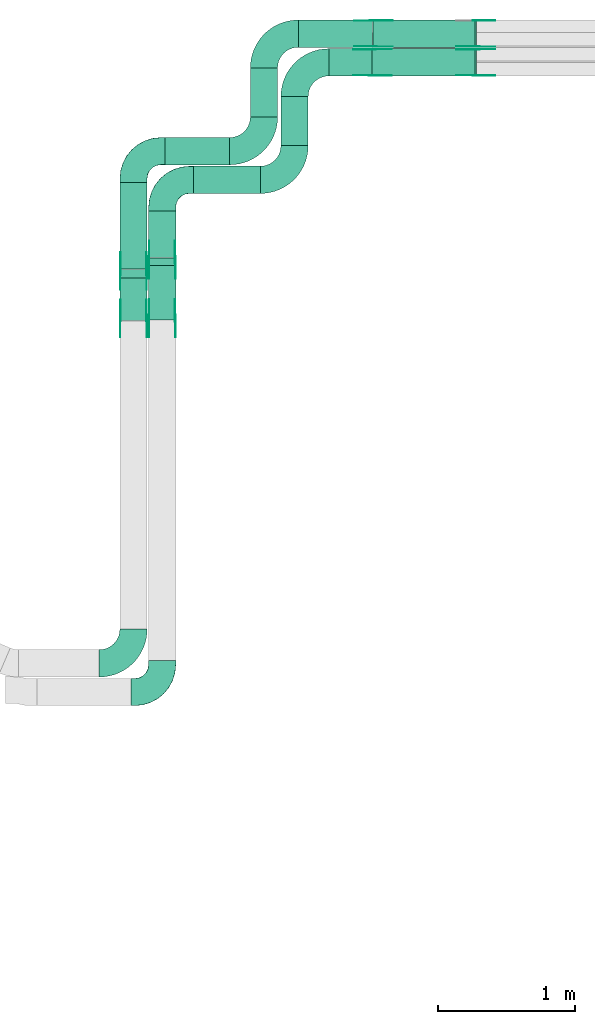
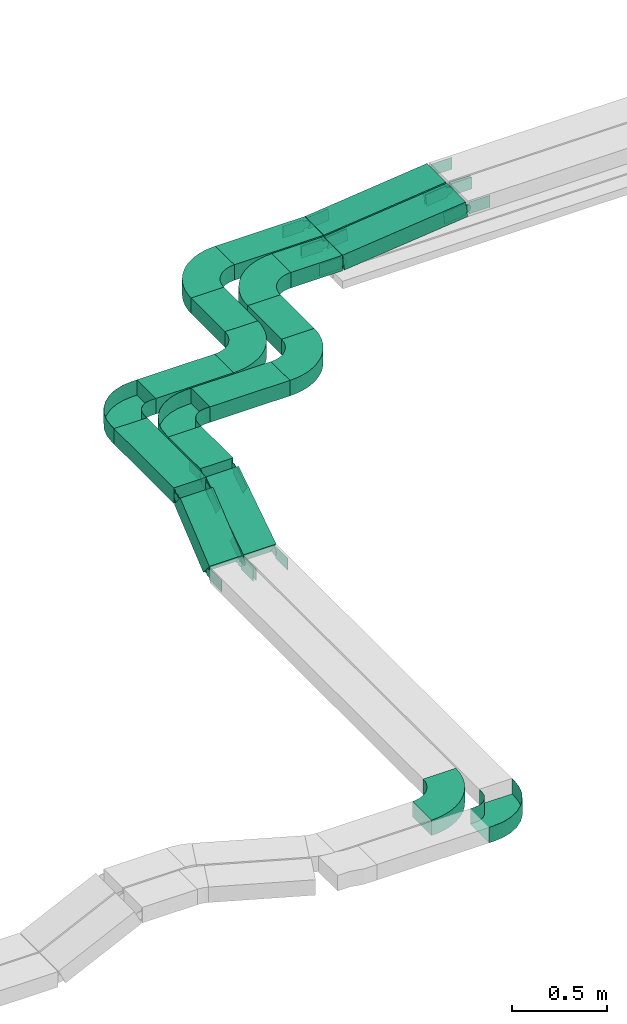
# One storey, part 15 of 23: 39 flow fittings, 12 flow segments.
"""IFC2X3 building model written with IfcOpenShell, lengths in millimetres."""

from ifc_helpers import new_model, entity, si_unit, converted_unit, derived_unit, direction, frame, frame_2d, origin, origin_2d_with_axis, place, context, subcontext, project, spatial, polyline, circle_curve, parameter, trimmed, segment, composite_curve, rectangle, outline, extrude, faceted_brep, source, transform, mapped, material, type_object, type_shapes, element, save


model = new_model("IFC2X3")

# Units and contexts
model_context = context("Model", 3, precision=0.01, world=origin(), true_north=direction((6.12303176911189e-17, 1.0)))
body_context = subcontext(model_context, "Body", "Model", "MODEL_VIEW")
ifc_project = project(units=[si_unit("LENGTHUNIT", "METRE", prefix="MILLI"), si_unit("AREAUNIT", "SQUARE_METRE"), si_unit("VOLUMEUNIT", "CUBIC_METRE"), converted_unit("PLANEANGLEUNIT", "DEGREE", entity("IfcRatioMeasure", 0.0174532925199433), si_unit("PLANEANGLEUNIT", "RADIAN"), dimensions=[0, 0, 0, 0, 0, 0, 0]), si_unit("MASSUNIT", "GRAM", prefix="KILO"), derived_unit("MASSDENSITYUNIT", [(si_unit("MASSUNIT", "GRAM", prefix="KILO"), 1), (si_unit("LENGTHUNIT", "METRE"), -3)]), derived_unit("MOMENTOFINERTIAUNIT", [(si_unit("LENGTHUNIT", "METRE"), 4)]), si_unit("TIMEUNIT", "SECOND"), si_unit("FREQUENCYUNIT", "HERTZ"), si_unit("THERMODYNAMICTEMPERATUREUNIT", "DEGREE_CELSIUS"), derived_unit("THERMALTRANSMITTANCEUNIT", [(si_unit("MASSUNIT", "GRAM", prefix="KILO"), 1), (si_unit("THERMODYNAMICTEMPERATUREUNIT", "KELVIN"), -1), (si_unit("TIMEUNIT", "SECOND"), -3)]), derived_unit("VOLUMETRICFLOWRATEUNIT", [(si_unit("LENGTHUNIT", "METRE"), 3), (si_unit("TIMEUNIT", "SECOND"), -1)]), derived_unit("MASSFLOWRATEUNIT", [(si_unit("MASSUNIT", "GRAM", prefix="KILO"), 1), (si_unit("TIMEUNIT", "SECOND"), -1)]), derived_unit("ROTATIONALFREQUENCYUNIT", [(si_unit("TIMEUNIT", "SECOND"), -1)]), si_unit("ELECTRICCURRENTUNIT", "AMPERE"), si_unit("ELECTRICVOLTAGEUNIT", "VOLT"), si_unit("POWERUNIT", "WATT"), si_unit("FORCEUNIT", "NEWTON", prefix="KILO"), si_unit("ILLUMINANCEUNIT", "LUX"), si_unit("LUMINOUSFLUXUNIT", "LUMEN"), si_unit("LUMINOUSINTENSITYUNIT", "CANDELA"), derived_unit("USERDEFINED", [(si_unit("MASSUNIT", "GRAM", prefix="KILO"), -1), (si_unit("LENGTHUNIT", "METRE"), -2), (si_unit("TIMEUNIT", "SECOND"), 3), (si_unit("LUMINOUSFLUXUNIT", "LUMEN"), 1)]), derived_unit("LINEARVELOCITYUNIT", [(si_unit("LENGTHUNIT", "METRE"), 1), (si_unit("TIMEUNIT", "SECOND"), -1)]), si_unit("PRESSUREUNIT", "PASCAL"), derived_unit("USERDEFINED", [(si_unit("LENGTHUNIT", "METRE"), -2), (si_unit("MASSUNIT", "GRAM", prefix="KILO"), 1), (si_unit("TIMEUNIT", "SECOND"), -2)]), derived_unit("LINEARFORCEUNIT", [(si_unit("MASSUNIT", "GRAM", prefix="KILO"), 1), (si_unit("LENGTHUNIT", "METRE"), 1), (si_unit("TIMEUNIT", "SECOND"), -2), (si_unit("LENGTHUNIT", "METRE"), -1)]), derived_unit("PLANARFORCEUNIT", [(si_unit("MASSUNIT", "GRAM", prefix="KILO"), 1), (si_unit("LENGTHUNIT", "METRE"), 1), (si_unit("TIMEUNIT", "SECOND"), -2), (si_unit("LENGTHUNIT", "METRE"), -2)])], contexts=[model_context])

# Site, building, storey
site_placement = place(None, origin())
site = spatial("IfcSite", under=ifc_project, at=site_placement, CompositionType="ELEMENT")
building_placement = place(site_placement, origin())
building = spatial("IfcBuilding", under=site, at=building_placement, CompositionType="ELEMENT")
storey_placement = place(building_placement, frame((0.0, 0.0, 24000.0)))
storey = spatial("IfcBuildingStorey", under=building, at=storey_placement, CompositionType="ELEMENT", Elevation=24000.0)

# Flow segments
cable_carrier_segment_type = type_object("IfcCableCarrierSegmentType", PredefinedType="CABLETRAYSEGMENT")
flow_segment_1_placement = place(storey_placement, frame((40330.6, 17371.8, 3163.62)))
element("IfcFlowSegment", 1, at=flow_segment_1_placement, inside=storey, type_object=cable_carrier_segment_type, context=body_context, shape_type="SweptSolid", body=[
    extrude(rectangle(XDim=338.196584381319, YDim=200.000000000007, at=origin_2d_with_axis()), frame((100.0, 169.1, 0.0), z_axis=(0.0, 0.0, 1.0), x_axis=(0.0, 1.0, 0.0)), (0.0, 0.0, 1.0), 99.9999999999989),
])
flow_segment_2_placement = place(storey_placement, frame((40120.6, 17287.95, 3163.62)))
element("IfcFlowSegment", 2, at=flow_segment_2_placement, inside=storey, type_object=cable_carrier_segment_type, context=body_context, shape_type="SweptSolid", body=[
    extrude(rectangle(XDim=632.047532657661, YDim=200.000000000007, at=origin_2d_with_axis()), frame((100.0, 316.02, 0.0), z_axis=(0.0, 0.0, 1.0), x_axis=(0.0, -1.0, 0.0)), (0.0, 0.0, 1.0), 100.000000000003),
])
flow_segment_3_placement = place(storey_placement, frame((40660.6, 17840.0, 3163.62)))
element("IfcFlowSegment", 3, at=flow_segment_3_placement, inside=storey, type_object=cable_carrier_segment_type, context=body_context, shape_type="SweptSolid", body=[
    extrude(rectangle(XDim=487.927271502945, YDim=200.000000000002, at=origin_2d_with_axis()), frame((243.96, 100.0, 0.0)), (0.0, 0.0, 1.0), 100.000000000003),
])
flow_segment_4_placement = place(storey_placement, frame((40450.6, 18050.0, 3163.62)))
element("IfcFlowSegment", 4, at=flow_segment_4_placement, inside=storey, type_object=cable_carrier_segment_type, context=body_context, shape_type="SweptSolid", body=[
    extrude(rectangle(XDim=474.11608127522, YDim=200.000000000002, at=origin_2d_with_axis()), frame((237.06, 100.0, 0.0)), (0.0, 0.0, 1.0), 100.000000000003),
])
flow_segment_5_placement = place(storey_placement, frame((40120.6, 16911.75, 2908.0)))
element("IfcFlowSegment", 5, at=flow_segment_5_placement, inside=storey, type_object=cable_carrier_segment_type, context=body_context, shape_type="SweptSolid", body=[
    extrude(rectangle(XDim=100.000000000003, YDim=399.48780758858, at=frame_2d((0.0, 0.0), x_axis=(0.0, 1.0))), frame((0.0, 185.94, 165.62), z_axis=(1.0, 0.0, 0.0), x_axis=(0.0, 0.771695487741885, 0.63599219664931)), (0.0, 0.0, 1.0), 200.000000000006),
])
flow_segment_6_placement = place(storey_placement, frame((40330.6, 16914.72, 2901.21)))
element("IfcFlowSegment", 6, at=flow_segment_6_placement, inside=storey, type_object=cable_carrier_segment_type, context=body_context, shape_type="SweptSolid", body=[
    extrude(rectangle(XDim=99.9999999999991, YDim=476.228564932628, at=frame_2d((0.0, 0.0), x_axis=(0.0, 1.0))), frame((0.0, 226.53, 172.41), z_axis=(1.0, 0.0, 0.0), x_axis=(0.0, 0.836155462391767, 0.548492518374144)), (0.0, 0.0, 1.0), 200.000000000006),
])
flow_segment_7_placement = place(storey_placement, frame((41299.53, 18191.0, 3163.62)))
element("IfcFlowSegment", 7, at=flow_segment_7_placement, inside=storey, type_object=cable_carrier_segment_type, context=body_context, shape_type="SweptSolid", body=[
    extrude(rectangle(XDim=358.000000000016, YDim=200.000000000007, at=origin_2d_with_axis()), frame((100.0, 179.0, 0.0), z_axis=(0.0, 0.0, 1.0), x_axis=(0.0, 1.0, 0.0)), (0.0, 0.0, 1.0), 100.000000000003),
])
flow_segment_8_placement = place(storey_placement, frame((41075.72, 18401.0, 3163.62)))
element("IfcFlowSegment", 8, at=flow_segment_8_placement, inside=storey, type_object=cable_carrier_segment_type, context=body_context, shape_type="SweptSolid", body=[
    extrude(rectangle(XDim=358.000000000023, YDim=200.000000000007, at=origin_2d_with_axis()), frame((100.0, 179.0, 0.0), z_axis=(0.0, 0.0, 1.0), x_axis=(0.0, 1.0, 0.0)), (0.0, 0.0, 1.0), 100.000000000003),
])
flow_segment_9_placement = place(storey_placement, frame((41650.53, 18700.0, 3163.62)))
element("IfcFlowSegment", 9, at=flow_segment_9_placement, inside=storey, type_object=cable_carrier_segment_type, context=body_context, shape_type="SweptSolid", body=[
    extrude(rectangle(XDim=314.053975483834, YDim=199.999999999998, at=origin_2d_with_axis()), frame((157.03, 100.0, 0.0)), (0.0, 0.0, 1.0), 100.000000000003),
])
flow_segment_10_placement = place(storey_placement, frame((41426.72, 18910.0, 3163.62)))
element("IfcFlowSegment", 10, at=flow_segment_10_placement, inside=storey, type_object=cable_carrier_segment_type, context=body_context, shape_type="SweptSolid", body=[
    extrude(rectangle(XDim=545.075260830746, YDim=200.000000000002, at=origin_2d_with_axis()), frame((272.54, 100.0, 0.0)), (0.0, 0.0, 1.0), 100.000000000003),
])
flow_segment_11_placement = place(storey_placement, frame((41967.0, 18700.0, 3164.32)))
element("IfcFlowSegment", 11, at=flow_segment_11_placement, inside=storey, type_object=cable_carrier_segment_type, context=body_context, shape_type="SweptSolid", body=[
    extrude(rectangle(XDim=99.9999999999953, YDim=199.999999999998, at=origin_2d_with_axis()), frame((5.35, 100.0, 49.71), z_axis=(0.994260088992235, 0.0, 0.106990071675617), x_axis=(-0.106990071675617, 0.0, 0.994260088992235)), (0.0, 0.0, 1.0), 756.593423660449),
])
flow_segment_12_placement = place(storey_placement, frame((41974.22, 18910.0, 3164.34)))
element("IfcFlowSegment", 12, at=flow_segment_12_placement, inside=storey, type_object=cable_carrier_segment_type, context=body_context, shape_type="SweptSolid", body=[
    extrude(rectangle(XDim=100.0, YDim=200.000000000002, at=origin_2d_with_axis()), frame((5.4, 100.0, 49.71), z_axis=(0.994150151497607, 0.0, 0.108006834400818), x_axis=(-0.108006834400818, 0.0, 0.994150151497607)), (0.0, 0.0, 1.0), 749.342190250516),
])

# Flow fittings
ifc_material_1 = material()
cable_carrier_fitting_type_1 = type_object("IfcCableCarrierFittingType", Name="470_DKC_S5_CPO 45 horizontal angle:-", PredefinedType="NOTDEFINED", material=ifc_material_1)
shared_shape_1 = source(origin(), body_context, "Body", "Brep", [
    faceted_brep([(-230.0, -99.2, -49.2), (-230.0, 99.2, -49.2), (-230.0, 99.2, 50.0), (-230.0, 100.0, 50.0), (-230.0, 100.0, -50.0), (-230.0, -100.0, -50.0), (-230.0, -100.0, 50.0), (-230.0, -99.2, 50.0), (-200.0, -100.0, -50.0), (-200.0, -100.0, 50.0), (-141.47, -94.24, 50.0), (-85.19, -77.16, 50.0), (-33.33, -49.44, 50.0), (12.13, -12.13, 50.0), (49.44, 33.33, 50.0), (77.16, 85.19, 50.0), (94.24, 141.47, 50.0), (100.0, 200.0, 50.0), (100.0, 230.0, 50.0), (99.2, 230.0, 50.0), (99.2, 200.0, 50.0), (93.45, 141.63, 50.0), (76.42, 85.5, 50.0), (48.78, 33.77, 50.0), (11.57, -11.57, 50.0), (-33.77, -48.78, 50.0), (-85.5, -76.42, 50.0), (-141.63, -93.45, 50.0), (-200.0, -99.2, 50.0), (-200.0, 99.2, 50.0), (-168.85, 104.13, 50.0), (-140.75, 118.45, 50.0), (-118.45, 140.75, 50.0), (-104.13, 168.85, 50.0), (-99.2, 200.0, 50.0), (-99.2, 230.0, 50.0), (-100.0, 230.0, 50.0), (-100.0, 200.0, 50.0), (-104.89, 169.1, 50.0), (-119.1, 141.22, 50.0), (-141.22, 119.1, 50.0), (-169.1, 104.89, 50.0), (-200.0, 100.0, 50.0), (-200.0, -99.2, -49.2), (-141.63, -93.45, -49.2), (-85.5, -76.42, -49.2), (-33.77, -48.78, -49.2), (11.57, -11.57, -49.2), (48.78, 33.77, -49.2), (76.42, 85.5, -49.2), (93.45, 141.63, -49.2), (99.2, 200.0, -49.2), (99.2, 230.0, -49.2), (-99.2, 230.0, -49.2), (-99.2, 200.0, -49.2), (-104.13, 168.85, -49.2), (-118.45, 140.75, -49.2), (-140.75, 118.45, -49.2), (-168.85, 104.13, -49.2), (-200.0, 99.2, -49.2), (-200.0, 100.0, -50.0), (-141.47, -94.24, -50.0), (-169.1, 104.89, -50.0), (-141.22, 119.1, -50.0), (-119.1, 141.22, -50.0), (-104.89, 169.1, -50.0), (-100.0, 200.0, -50.0), (-100.0, 230.0, -50.0), (100.0, 230.0, -50.0), (100.0, 200.0, -50.0), (94.24, 141.47, -50.0), (77.16, 85.19, -50.0), (49.44, 33.33, -50.0), (12.13, -12.13, -50.0), (-33.33, -49.44, -50.0), (-85.19, -77.16, -50.0)], [[[0, 1, 2, 3, 4, 5, 6, 7]], [[6, 5, 8, 9]], [[7, 6, 9, 10, 11, 12, 13, 14, 15, 16, 17, 18, 19, 20, 21, 22, 23, 24, 25, 26, 27, 28]], [[3, 2, 29, 30, 31, 32, 33, 34, 35, 36, 37, 38, 39, 40, 41, 42]], [[0, 7, 28, 43]], [[1, 0, 43, 44, 45, 46, 47, 48, 49, 50, 51, 52, 53, 54, 55, 56, 57, 58, 59]], [[2, 1, 59, 29]], [[4, 3, 42, 60]], [[61, 8, 5, 4, 60, 62, 63, 64, 65, 66, 67, 68, 69, 70, 71, 72, 73, 74, 75]], [[10, 9, 8, 61]], [[61, 75, 11, 10]], [[74, 12, 11, 75]], [[73, 13, 12, 74]], [[14, 72, 71, 15]], [[15, 71, 70, 16]], [[16, 70, 69, 17]], [[73, 72, 14, 13]], [[44, 43, 28, 27]], [[26, 45, 44, 27]], [[45, 26, 25, 46]], [[25, 24, 47, 46]], [[49, 48, 23, 22]], [[50, 49, 22, 21]], [[51, 50, 21, 20]], [[24, 23, 48, 47]], [[58, 57, 31, 30]], [[59, 58, 30, 29]], [[57, 56, 32, 31]], [[32, 56, 55, 33]], [[33, 55, 54, 34]], [[41, 40, 63, 62]], [[41, 62, 60, 42]], [[40, 39, 64, 63]], [[65, 64, 39, 38]], [[66, 65, 38, 37]], [[67, 36, 35, 53, 52, 19, 18, 68]], [[17, 69, 68, 18]], [[51, 20, 19, 52]], [[34, 54, 53, 35]], [[66, 37, 36, 67]]]),
])
type_shapes(cable_carrier_fitting_type_1, [shared_shape_1])
for number, where, z_axis, x_axis, name in (
    (13, (40430.6, 17940.0, 3213.62), (0.0, 0.0, 1.0), (-1.0, 0.0, 0.0), "470_DKC_S5_45 horizontal angle"),
    (14, (40220.6, 18150.0, 3213.62), (0.0, 0.0, 1.0), (-1.0, 0.0, 0.0), "470_DKC_S5_45 horizontal angle"),
):
    element("IfcFlowFitting", number, at=place(storey_placement, frame(where, z_axis=z_axis, x_axis=x_axis)), inside=storey, type_object=cable_carrier_fitting_type_1, material=ifc_material_1, Name=name, ObjectType="470_DKC_S5_CPO 45 horizontal angle:-", context=body_context, shape_type="MappedRepresentation", body=[
        mapped(shared_shape_1, transform((0.0, 0.0, 0.0), scale=1.0)),
    ])
flow_fitting_1_placement = place(storey_placement, frame((40430.6, 14190.31, 2933.62)))
element("IfcFlowFitting", 15, at=flow_fitting_1_placement, inside=storey, type_object=cable_carrier_fitting_type_1, material=ifc_material_1, Name="470_DKC_S5_45 horizontal angle", ObjectType="470_DKC_S5_CPO 45 horizontal angle:-", context=body_context, shape_type="MappedRepresentation", body=[
    mapped(shared_shape_1, transform((0.0, 0.0, 0.0), scale=1.0)),
])
cable_carrier_fitting_type_2 = type_object("IfcCableCarrierFittingType", Name="470_DKC_S5_Variable Angle Elbow 0-45:-", PredefinedType="NOTDEFINED", material=ifc_material_1)
shared_shape_2 = source(origin(), body_context, "Body", "SweptSolid", [
    extrude(outline(composite_curve([segment(polyline([(-125.75, -225.25), (-124.75, -225.25)]), True, "CONTINUOUS"), segment(trimmed(circle_curve(frame_2d((-124.75, 124.75), x_axis=(0.0, -1.0)), 350.0), [parameter(0.0)], [parameter(90.0000000000001)], True, "PARAMETER"), True, "CONTINUOUS"), segment(polyline([(225.25, 124.75), (225.25, 125.75)]), True, "CONTINUOUS"), segment(polyline([(225.25, 125.75), (25.25, 125.75)]), True, "CONTINUOUS"), segment(polyline([(25.25, 125.75), (25.25, 124.75)]), True, "CONTINUOUS"), segment(trimmed(circle_curve(frame_2d((-124.75, 124.75), x_axis=(0.0, -1.0)), 150.0), [parameter(0.0)], [parameter(90.0000000000001)], True, "PARAMETER"), False, "CONTINUOUS"), segment(polyline([(-124.75, -25.25), (-125.75, -25.25)]), True, "CONTINUOUS"), segment(polyline([(-125.75, -25.25), (-125.75, -225.25)]), True, "CONTINUOUS")], self_intersect=False)), frame((-125.25, 125.25, -50.0)), (0.0, 0.0, 1.0), 100.0),
])
type_shapes(cable_carrier_fitting_type_2, [shared_shape_2])
for number, where, name in (
    (16, (41399.53, 17940.0, 3213.62), "470_DKC_S5_Variable Angle Elbow 0-45:-"),
    (17, (41175.72, 18150.0, 3213.62), "470_DKC_S5_Variable Angle Elbow 0-45:-"),
    (18, (40220.6, 14400.31, 2933.62), "470_DKC_S5_Variable Angle Elbow 0-45:-"),
):
    element("IfcFlowFitting", number, at=place(storey_placement, frame(where)), inside=storey, type_object=cable_carrier_fitting_type_2, material=ifc_material_1, Name=name, ObjectType="470_DKC_S5_Variable Angle Elbow 0-45:-", context=body_context, shape_type="MappedRepresentation", body=[
        mapped(shared_shape_2, transform((0.0, 0.0, 0.0), scale=1.0)),
    ])
for number, where, z_axis, x_axis, name in (
    (19, (41399.53, 18800.0, 3213.62), (0.0, 0.0, 1.0), (-1.0, 0.0, 0.0), "470_DKC_S5_Variable Angle Elbow 0-45:-"),
    (20, (41175.72, 19010.0, 3213.62), (0.0, 0.0, 1.0), (-1.0, 0.0, 0.0), "470_DKC_S5_Variable Angle Elbow 0-45:-"),
):
    element("IfcFlowFitting", number, at=place(storey_placement, frame(where, z_axis=z_axis, x_axis=x_axis)), inside=storey, type_object=cable_carrier_fitting_type_2, material=ifc_material_1, Name=name, ObjectType="470_DKC_S5_Variable Angle Elbow 0-45:-", context=body_context, shape_type="MappedRepresentation", body=[
        mapped(shared_shape_2, transform((0.0, 0.0, 0.0), scale=1.0)),
    ])
ifc_material_2 = material(Name="G")
cable_carrier_fitting_type_3 = type_object("IfcCableCarrierFittingType", PredefinedType="NOTDEFINED", material=ifc_material_2)
shared_shape_3 = source(origin(), body_context, "Body", "SweptSolid", [
    extrude(outline(composite_curve([segment(trimmed(circle_curve(frame_2d((-41.47, 0.0), x_axis=(1.0, 0.0)), 25.0), [parameter(90.0000000000007)], [parameter(270.0)], True, "PARAMETER"), True, "CONTINUOUS"), segment(polyline([(-41.47, -25.0), (-29.97, -25.0)]), True, "CONTINUOUS"), segment(polyline([(-29.97, -25.0), (-28.1, -38.5)]), True, "CONTINUOUS"), segment(polyline([(-28.1, -38.5), (99.53, -38.5)]), True, "CONTINUOUS"), segment(polyline([(99.53, -38.5), (99.53, 38.5)]), True, "CONTINUOUS"), segment(polyline([(99.53, 38.5), (-28.1, 38.5)]), True, "CONTINUOUS"), segment(polyline([(-28.1, 38.5), (-29.97, 25.0)]), True, "CONTINUOUS"), segment(polyline([(-29.97, 25.0), (-41.47, 25.0)]), True, "CONTINUOUS")], self_intersect=False)), frame((41.47, 0.0, 0.0), z_axis=(0.0, 0.0, -1.0), x_axis=(1.0, 0.0, 0.0)), (0.0, 0.0, -1.0), 2.0),
])
type_shapes(cable_carrier_fitting_type_3, [shared_shape_3])
flow_fitting_2_placement = place(storey_placement, frame((40526.06, 17354.67, 3213.62), z_axis=(1.0, 0.0, 0.0), x_axis=(0.0, -0.836155462391787, -0.548492518374114)))
element("IfcFlowFitting", 21, at=flow_fitting_2_placement, inside=storey, type_object=cable_carrier_fitting_type_3, material=ifc_material_2, context=body_context, shape_type="MappedRepresentation", body=[
    mapped(shared_shape_3, transform((0.0, 0.0, 0.0), scale=1.0)),
])
cable_carrier_fitting_type_4 = type_object("IfcCableCarrierFittingType", PredefinedType="NOTDEFINED", material=ifc_material_2)
type_shapes(cable_carrier_fitting_type_4, [shared_shape_3])
flow_fitting_3_placement = place(storey_placement, frame((40337.14, 17354.67, 3213.62), z_axis=(-1.0, 0.0, 0.0), x_axis=(0.0, 1.0, 0.0)))
element("IfcFlowFitting", 22, at=flow_fitting_3_placement, inside=storey, type_object=cable_carrier_fitting_type_4, material=ifc_material_2, context=body_context, shape_type="MappedRepresentation", body=[
    mapped(shared_shape_3, transform((0.0, 0.0, 0.0), scale=1.0)),
])
flow_fitting_4_placement = place(storey_placement, frame((40316.06, 17267.57, 3213.62), z_axis=(1.0, 0.0, 0.0), x_axis=(0.0, -0.771695487741913, -0.635992196649276)))
element("IfcFlowFitting", 23, at=flow_fitting_4_placement, inside=storey, type_object=cable_carrier_fitting_type_3, material=ifc_material_2, context=body_context, shape_type="MappedRepresentation", body=[
    mapped(shared_shape_3, transform((0.0, 0.0, 0.0), scale=1.0)),
])
flow_fitting_5_placement = place(storey_placement, frame((40127.14, 17267.57, 3213.62), z_axis=(-1.0, 0.0, 0.0), x_axis=(0.0, 1.0, 0.0)))
element("IfcFlowFitting", 24, at=flow_fitting_5_placement, inside=storey, type_object=cable_carrier_fitting_type_4, material=ifc_material_2, context=body_context, shape_type="MappedRepresentation", body=[
    mapped(shared_shape_3, transform((0.0, 0.0, 0.0), scale=1.0)),
])
flow_fitting_6_placement = place(storey_placement, frame((40125.14, 16927.82, 2933.62), z_axis=(-1.0, 0.0, 0.0), x_axis=(0.0, -1.0, 0.0)))
element("IfcFlowFitting", 25, at=flow_fitting_6_placement, inside=storey, type_object=cable_carrier_fitting_type_3, material=ifc_material_2, context=body_context, shape_type="MappedRepresentation", body=[
    mapped(shared_shape_3, transform((0.0, 0.0, 0.0), scale=1.0)),
])
flow_fitting_7_placement = place(storey_placement, frame((40314.06, 16927.82, 2933.62), z_axis=(1.0, 0.0, 0.0), x_axis=(0.0, 0.771695487741889, 0.635992196649305)))
element("IfcFlowFitting", 26, at=flow_fitting_7_placement, inside=storey, type_object=cable_carrier_fitting_type_4, material=ifc_material_2, context=body_context, shape_type="MappedRepresentation", body=[
    mapped(shared_shape_3, transform((0.0, 0.0, 0.0), scale=1.0)),
])
flow_fitting_8_placement = place(storey_placement, frame((40335.14, 16927.82, 2933.62), z_axis=(-1.0, 0.0, 0.0), x_axis=(0.0, -1.0, 0.0)))
element("IfcFlowFitting", 27, at=flow_fitting_8_placement, inside=storey, type_object=cable_carrier_fitting_type_3, material=ifc_material_2, context=body_context, shape_type="MappedRepresentation", body=[
    mapped(shared_shape_3, transform((0.0, 0.0, 0.0), scale=1.0)),
])
flow_fitting_9_placement = place(storey_placement, frame((40524.06, 16927.82, 2933.62), z_axis=(1.0, 0.0, 0.0), x_axis=(0.0, 0.83615546239177, 0.548492518374139)))
element("IfcFlowFitting", 28, at=flow_fitting_9_placement, inside=storey, type_object=cable_carrier_fitting_type_4, material=ifc_material_2, context=body_context, shape_type="MappedRepresentation", body=[
    mapped(shared_shape_3, transform((0.0, 0.0, 0.0), scale=1.0)),
])
flow_fitting_10_placement = place(storey_placement, frame((41968.48, 18704.54, 3213.62), z_axis=(0.0, -1.0, 0.0), x_axis=(0.994260088992224, 0.0, 0.106990071675716)))
element("IfcFlowFitting", 29, at=flow_fitting_10_placement, inside=storey, type_object=cable_carrier_fitting_type_3, material=ifc_material_2, context=body_context, shape_type="MappedRepresentation", body=[
    mapped(shared_shape_3, transform((0.0, 0.0, 0.0), scale=1.0)),
])
flow_fitting_11_placement = place(storey_placement, frame((41968.48, 18893.46, 3213.62), z_axis=(0.0, 1.0, 0.0), x_axis=(-1.0, 0.0, 0.0)))
element("IfcFlowFitting", 30, at=flow_fitting_11_placement, inside=storey, type_object=cable_carrier_fitting_type_4, material=ifc_material_2, context=body_context, shape_type="MappedRepresentation", body=[
    mapped(shared_shape_3, transform((0.0, 0.0, 0.0), scale=1.0)),
])
flow_fitting_12_placement = place(storey_placement, frame((41975.72, 18914.54, 3213.62), z_axis=(0.0, -1.0, 0.0), x_axis=(0.994150151497606, 0.0, 0.108006834400827)))
element("IfcFlowFitting", 31, at=flow_fitting_12_placement, inside=storey, type_object=cable_carrier_fitting_type_3, material=ifc_material_2, context=body_context, shape_type="MappedRepresentation", body=[
    mapped(shared_shape_3, transform((0.0, 0.0, 0.0), scale=1.0)),
])
flow_fitting_13_placement = place(storey_placement, frame((41975.72, 19103.46, 3213.62), z_axis=(0.0, 1.0, 0.0), x_axis=(-1.0, 0.0, 0.0)))
element("IfcFlowFitting", 32, at=flow_fitting_13_placement, inside=storey, type_object=cable_carrier_fitting_type_4, material=ifc_material_2, context=body_context, shape_type="MappedRepresentation", body=[
    mapped(shared_shape_3, transform((0.0, 0.0, 0.0), scale=1.0)),
])
flow_fitting_14_placement = place(storey_placement, frame((42728.48, 18895.46, 3295.4), z_axis=(0.0, 1.0, 0.0), x_axis=(1.0, 0.0, 0.0)))
element("IfcFlowFitting", 33, at=flow_fitting_14_placement, inside=storey, type_object=cable_carrier_fitting_type_3, material=ifc_material_2, context=body_context, shape_type="MappedRepresentation", body=[
    mapped(shared_shape_3, transform((0.0, 0.0, 0.0), scale=1.0)),
])
flow_fitting_15_placement = place(storey_placement, frame((42728.48, 18706.54, 3295.4), z_axis=(0.0, -1.0, 0.0), x_axis=(-0.994260088992227, 0.0, -0.106990071675685)))
element("IfcFlowFitting", 34, at=flow_fitting_15_placement, inside=storey, type_object=cable_carrier_fitting_type_4, material=ifc_material_2, context=body_context, shape_type="MappedRepresentation", body=[
    mapped(shared_shape_3, transform((0.0, 0.0, 0.0), scale=1.0)),
])
flow_fitting_16_placement = place(storey_placement, frame((42728.48, 19105.46, 3295.4), z_axis=(0.0, 1.0, 0.0), x_axis=(1.0, 0.0, 0.0)))
element("IfcFlowFitting", 35, at=flow_fitting_16_placement, inside=storey, type_object=cable_carrier_fitting_type_3, material=ifc_material_2, context=body_context, shape_type="MappedRepresentation", body=[
    mapped(shared_shape_3, transform((0.0, 0.0, 0.0), scale=1.0)),
])
flow_fitting_17_placement = place(storey_placement, frame((42728.48, 18916.54, 3295.4), z_axis=(0.0, -1.0, 0.0), x_axis=(-0.99415015149761, 0.0, -0.10800683440079)))
element("IfcFlowFitting", 36, at=flow_fitting_17_placement, inside=storey, type_object=cable_carrier_fitting_type_4, material=ifc_material_2, context=body_context, shape_type="MappedRepresentation", body=[
    mapped(shared_shape_3, transform((0.0, 0.0, 0.0), scale=1.0)),
])
cable_carrier_fitting_type_5 = type_object("IfcCableCarrierFittingType", PredefinedType="NOTDEFINED", material=ifc_material_2)
shared_shape_4 = source(origin(), body_context, "Body", "SweptSolid", [
    extrude(outline(composite_curve([segment(trimmed(circle_curve(frame_2d((-41.47, 0.0), x_axis=(1.0, 0.0)), 25.0), [parameter(90.0000000000007)], [parameter(270.0)], True, "PARAMETER"), True, "CONTINUOUS"), segment(polyline([(-41.47, -25.0), (-29.97, -25.0)]), True, "CONTINUOUS"), segment(polyline([(-29.97, -25.0), (-28.1, -38.5)]), True, "CONTINUOUS"), segment(polyline([(-28.1, -38.5), (99.53, -38.5)]), True, "CONTINUOUS"), segment(polyline([(99.53, -38.5), (99.53, 38.5)]), True, "CONTINUOUS"), segment(polyline([(99.53, 38.5), (-28.1, 38.5)]), True, "CONTINUOUS"), segment(polyline([(-28.1, 38.5), (-29.97, 25.0)]), True, "CONTINUOUS"), segment(polyline([(-29.97, 25.0), (-41.47, 25.0)]), True, "CONTINUOUS")], self_intersect=False)), frame((41.47, 0.0, 0.0)), (0.0, 0.0, 1.0), 2.0),
])
type_shapes(cable_carrier_fitting_type_5, [shared_shape_4])
flow_fitting_18_placement = place(storey_placement, frame((40335.14, 17354.67, 3213.62), z_axis=(-1.0, 0.0, 0.0), x_axis=(0.0, -0.836155462391787, -0.548492518374114)))
element("IfcFlowFitting", 37, at=flow_fitting_18_placement, inside=storey, type_object=cable_carrier_fitting_type_5, material=ifc_material_2, context=body_context, shape_type="MappedRepresentation", body=[
    mapped(shared_shape_4, transform((0.0, 0.0, 0.0), scale=1.0)),
])
cable_carrier_fitting_type_6 = type_object("IfcCableCarrierFittingType", PredefinedType="NOTDEFINED", material=ifc_material_2)
type_shapes(cable_carrier_fitting_type_6, [shared_shape_4])
flow_fitting_19_placement = place(storey_placement, frame((40524.06, 17354.67, 3213.62), z_axis=(1.0, 0.0, 0.0), x_axis=(0.0, 1.0, 0.0)))
element("IfcFlowFitting", 38, at=flow_fitting_19_placement, inside=storey, type_object=cable_carrier_fitting_type_6, material=ifc_material_2, context=body_context, shape_type="MappedRepresentation", body=[
    mapped(shared_shape_4, transform((0.0, 0.0, 0.0), scale=1.0)),
])
flow_fitting_20_placement = place(storey_placement, frame((40125.14, 17267.57, 3213.62), z_axis=(-1.0, 0.0, 0.0), x_axis=(0.0, -0.771695487741913, -0.635992196649276)))
element("IfcFlowFitting", 39, at=flow_fitting_20_placement, inside=storey, type_object=cable_carrier_fitting_type_5, material=ifc_material_2, context=body_context, shape_type="MappedRepresentation", body=[
    mapped(shared_shape_4, transform((0.0, 0.0, 0.0), scale=1.0)),
])
flow_fitting_21_placement = place(storey_placement, frame((40314.06, 17267.57, 3213.62), z_axis=(1.0, 0.0, 0.0), x_axis=(0.0, 1.0, 0.0)))
element("IfcFlowFitting", 40, at=flow_fitting_21_placement, inside=storey, type_object=cable_carrier_fitting_type_6, material=ifc_material_2, context=body_context, shape_type="MappedRepresentation", body=[
    mapped(shared_shape_4, transform((0.0, 0.0, 0.0), scale=1.0)),
])
flow_fitting_22_placement = place(storey_placement, frame((40316.06, 16927.82, 2933.62), z_axis=(1.0, 0.0, 0.0), x_axis=(0.0, -1.0, 0.0)))
element("IfcFlowFitting", 41, at=flow_fitting_22_placement, inside=storey, type_object=cable_carrier_fitting_type_5, material=ifc_material_2, context=body_context, shape_type="MappedRepresentation", body=[
    mapped(shared_shape_4, transform((0.0, 0.0, 0.0), scale=1.0)),
])
flow_fitting_23_placement = place(storey_placement, frame((40127.14, 16927.82, 2933.62), z_axis=(-1.0, 0.0, 0.0), x_axis=(0.0, 0.771695487741889, 0.635992196649305)))
element("IfcFlowFitting", 42, at=flow_fitting_23_placement, inside=storey, type_object=cable_carrier_fitting_type_6, material=ifc_material_2, context=body_context, shape_type="MappedRepresentation", body=[
    mapped(shared_shape_4, transform((0.0, 0.0, 0.0), scale=1.0)),
])
flow_fitting_24_placement = place(storey_placement, frame((40526.06, 16927.82, 2933.62), z_axis=(1.0, 0.0, 0.0), x_axis=(0.0, -1.0, 0.0)))
element("IfcFlowFitting", 43, at=flow_fitting_24_placement, inside=storey, type_object=cable_carrier_fitting_type_5, material=ifc_material_2, context=body_context, shape_type="MappedRepresentation", body=[
    mapped(shared_shape_4, transform((0.0, 0.0, 0.0), scale=1.0)),
])
flow_fitting_25_placement = place(storey_placement, frame((40337.14, 16927.82, 2933.62), z_axis=(-1.0, 0.0, 0.0), x_axis=(0.0, 0.83615546239177, 0.548492518374139)))
element("IfcFlowFitting", 44, at=flow_fitting_25_placement, inside=storey, type_object=cable_carrier_fitting_type_6, material=ifc_material_2, context=body_context, shape_type="MappedRepresentation", body=[
    mapped(shared_shape_4, transform((0.0, 0.0, 0.0), scale=1.0)),
])
flow_fitting_26_placement = place(storey_placement, frame((41968.48, 18895.46, 3213.62), z_axis=(0.0, 1.0, 0.0), x_axis=(0.994260088992224, 0.0, 0.106990071675716)))
element("IfcFlowFitting", 45, at=flow_fitting_26_placement, inside=storey, type_object=cable_carrier_fitting_type_5, material=ifc_material_2, context=body_context, shape_type="MappedRepresentation", body=[
    mapped(shared_shape_4, transform((0.0, 0.0, 0.0), scale=1.0)),
])
flow_fitting_27_placement = place(storey_placement, frame((41968.48, 18706.54, 3213.62), z_axis=(0.0, -1.0, 0.0), x_axis=(-1.0, 0.0, 0.0)))
element("IfcFlowFitting", 46, at=flow_fitting_27_placement, inside=storey, type_object=cable_carrier_fitting_type_6, material=ifc_material_2, context=body_context, shape_type="MappedRepresentation", body=[
    mapped(shared_shape_4, transform((0.0, 0.0, 0.0), scale=1.0)),
])
flow_fitting_28_placement = place(storey_placement, frame((41975.72, 19105.46, 3213.62), z_axis=(0.0, 1.0, 0.0), x_axis=(0.994150151497606, 0.0, 0.108006834400827)))
element("IfcFlowFitting", 47, at=flow_fitting_28_placement, inside=storey, type_object=cable_carrier_fitting_type_5, material=ifc_material_2, context=body_context, shape_type="MappedRepresentation", body=[
    mapped(shared_shape_4, transform((0.0, 0.0, 0.0), scale=1.0)),
])
flow_fitting_29_placement = place(storey_placement, frame((41975.72, 18916.54, 3213.62), z_axis=(0.0, -1.0, 0.0), x_axis=(-1.0, 0.0, 0.0)))
element("IfcFlowFitting", 48, at=flow_fitting_29_placement, inside=storey, type_object=cable_carrier_fitting_type_6, material=ifc_material_2, context=body_context, shape_type="MappedRepresentation", body=[
    mapped(shared_shape_4, transform((0.0, 0.0, 0.0), scale=1.0)),
])
flow_fitting_30_placement = place(storey_placement, frame((42728.48, 18704.54, 3295.4), z_axis=(0.0, -1.0, 0.0), x_axis=(1.0, 0.0, 0.0)))
element("IfcFlowFitting", 49, at=flow_fitting_30_placement, inside=storey, type_object=cable_carrier_fitting_type_5, material=ifc_material_2, context=body_context, shape_type="MappedRepresentation", body=[
    mapped(shared_shape_4, transform((0.0, 0.0, 0.0), scale=1.0)),
])
flow_fitting_31_placement = place(storey_placement, frame((42728.48, 18893.46, 3295.4), z_axis=(0.0, 1.0, 0.0), x_axis=(-0.994260088992227, 0.0, -0.106990071675685)))
element("IfcFlowFitting", 50, at=flow_fitting_31_placement, inside=storey, type_object=cable_carrier_fitting_type_6, material=ifc_material_2, context=body_context, shape_type="MappedRepresentation", body=[
    mapped(shared_shape_4, transform((0.0, 0.0, 0.0), scale=1.0)),
])
flow_fitting_32_placement = place(storey_placement, frame((42728.48, 18914.54, 3295.4), z_axis=(0.0, -1.0, 0.0), x_axis=(1.0, 0.0, 0.0)))
element("IfcFlowFitting", 51, at=flow_fitting_32_placement, inside=storey, type_object=cable_carrier_fitting_type_5, material=ifc_material_2, context=body_context, shape_type="MappedRepresentation", body=[
    mapped(shared_shape_4, transform((0.0, 0.0, 0.0), scale=1.0)),
])

save(model, "model.ifc")
